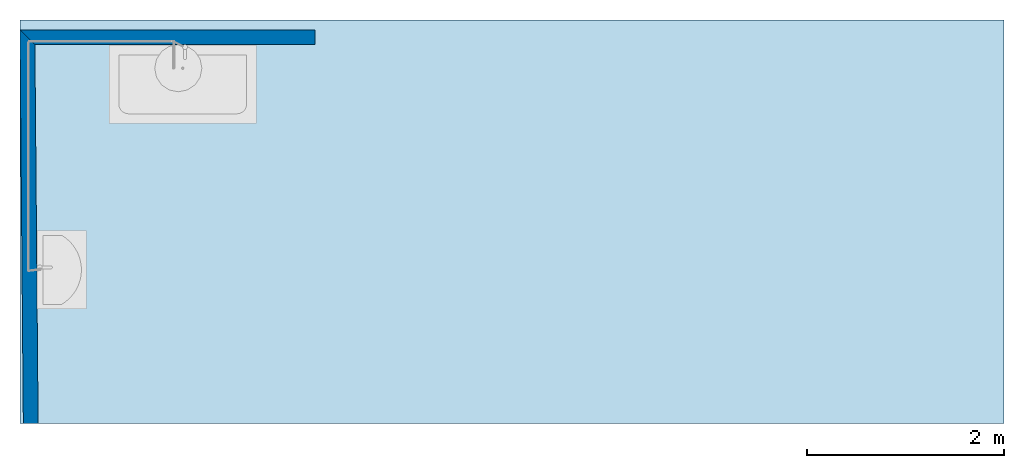
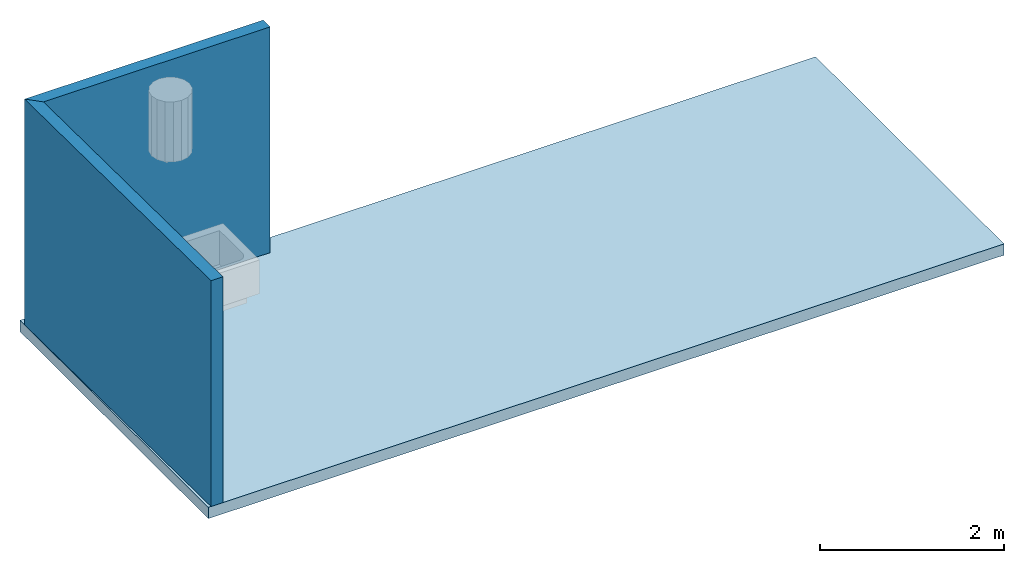
# One storey, part 1 of 3: 2 walls, 1 slab.
"""IFC4 building model written with IfcOpenShell, lengths in metres."""

from ifc_helpers import new_model, entity, si_unit, converted_unit, frame, origin_with_axes, origin_2d_with_axis, place, context, subcontext, project, spatial, line, indexed_curve, outline, extrude, material, layer, layer_set, layer_usage, type_object, element, save


model = new_model("IFC4")

# Units and contexts
model_context = context("Model", 3, precision=1e-05, world=origin_with_axes())
plan_context = context("Plan", 2, precision=1e-05, world=origin_2d_with_axis())
body_context = subcontext(model_context, "Body", "Model", "MODEL_VIEW")
ifc_project = project(units=[converted_unit("PLANEANGLEUNIT", "degree", entity("IfcReal", 0.0174532925199433), si_unit("PLANEANGLEUNIT", "RADIAN"), dimensions=[0, 0, 0, 0, 0, 0, 0]), si_unit("AREAUNIT", "SQUARE_METRE"), si_unit("VOLUMEUNIT", "CUBIC_METRE"), si_unit("LENGTHUNIT", "METRE")], contexts=[model_context, plan_context])

# Site, building, storey
site_placement = place(None, origin_with_axes())
site = spatial("IfcSite", under=ifc_project, at=site_placement)
building_placement = place(site_placement, origin_with_axes())
building = spatial("IfcBuilding", under=site, at=building_placement, Name="Building")
storey_placement = place(building_placement, origin_with_axes())
storey = spatial("IfcBuildingStorey", under=building, at=storey_placement, Name="Storey")

# Slab
ifc_material = material()
ifc_layer_1 = layer(ifc_material, 0.150000005960464)
ifc_layer_set_1 = layer_set([ifc_layer_1])
ifc_layer_usage_1 = layer_usage(ifc_layer_set_1, "AXIS3", "POSITIVE", -0.150000005960464)
slab_type = type_object("IfcSlabType", Name="SLB-150", PredefinedType="FLOOR", material=ifc_layer_set_1)
slab_placement = place(storey_placement, origin_with_axes())
element("IfcSlab", 1, at=slab_placement, inside=storey, type_object=slab_type, material=ifc_layer_usage_1, Name="150", context=body_context, shape_type="SweptSolid", body=[
    extrude(outline(indexed_curve([(0.0, 0.0), (0.0, 4.1), (10.0, 4.1), (10.0, 0.0), (0.0, 0.0)])), frame((0.0, 0.0, -0.150000005960464), z_axis=(0.0, 0.0, 1.0), x_axis=(1.0, 0.0, 0.0)), (0.0, 0.0, 1.0), 0.150000005960464),
])

# Walls
ifc_layer_2 = layer(ifc_material, 0.150000005960464)
ifc_layer_set_2 = layer_set([ifc_layer_2])
ifc_layer_usage_2 = layer_usage(ifc_layer_set_2, "AXIS2", "POSITIVE", 0.0)
wall_type = type_object("IfcWallType", Name="WAL-150", PredefinedType="SOLIDWALL", material=ifc_layer_set_2)
wall_1_placement = place(storey_placement, frame((0.151269204275489, 3.84999990463257, 0.0), z_axis=(0.0, 0.0, 1.0), x_axis=(1.0, 0.0, 0.0)))
element("IfcWall", 2, at=wall_1_placement, inside=storey, type_object=wall_type, material=ifc_layer_usage_2, Name="WAL-150", context=body_context, shape_type="SweptSolid", body=[
    extrude(outline(indexed_curve([(0.0, 0.0), (-0.15127980990376, 0.150000005960464), (2.84873079369892, 0.150000005960464), (2.84873079369892, 0.0)], segments=[line(1, 2, 3, 4, 1)])), origin_with_axes(), (0.0, 0.0, 1.0), 3.0),
])
ifc_layer_usage_3 = layer_usage(ifc_layer_set_2, "AXIS2", "POSITIVE", 0.0)
wall_2_placement = place(storey_placement, frame((0.18397855758667, -5.04275771191927e-19, 0.0), z_axis=(0.0, 0.0, 1.0), x_axis=(-0.00849562952974184, 0.999963911488256, 0.0)))
element("IfcWall", 3, at=wall_2_placement, inside=storey, type_object=wall_type, material=ifc_layer_usage_3, Name="WAL-150", context=body_context, shape_type="SweptSolid", body=[
    extrude(outline(indexed_curve([(0.0, 0.0), (0.0, 0.150000005960464), (4.00141866031745, 0.150000005960464), (3.85013885041369, 0.0)], segments=[line(1, 2, 3, 4, 1)])), origin_with_axes(), (0.0, 0.0, 1.0), 3.0),
])

save(model, "model.ifc")
